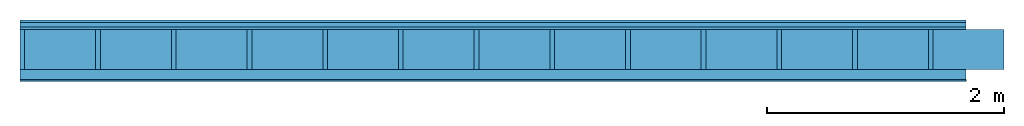
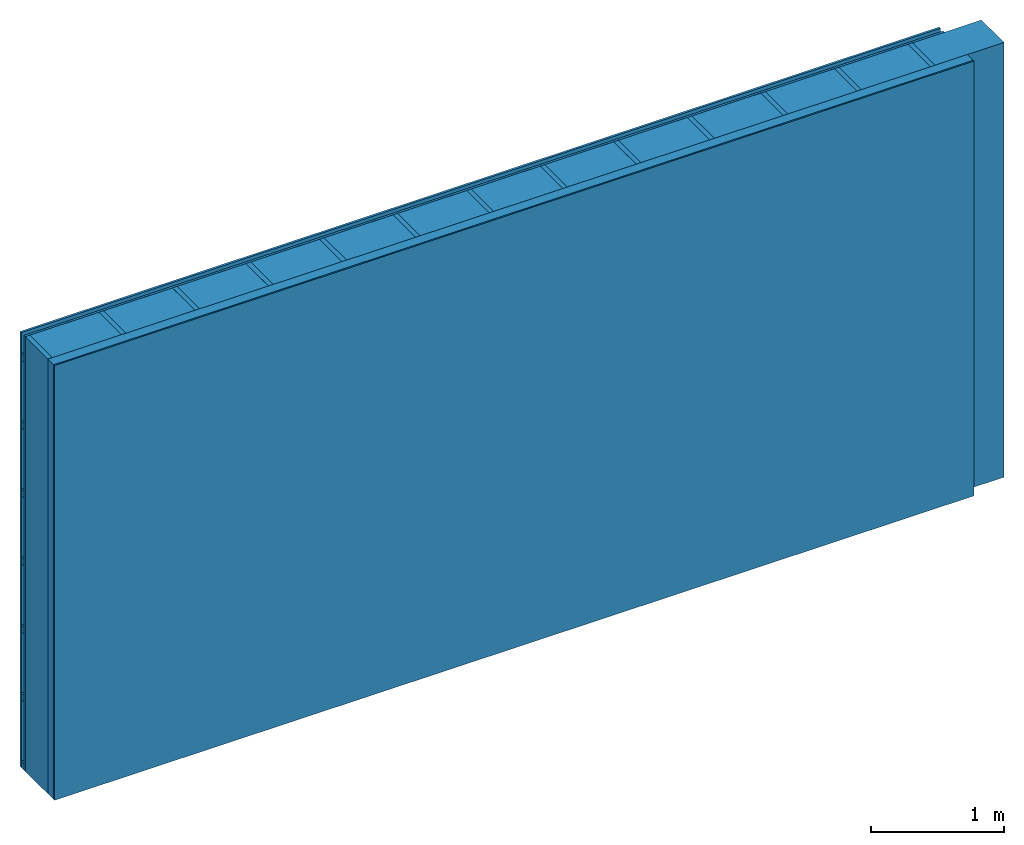
# One storey: 4 plates, 3 members, 1 element without a shape of its own.
"""IFC4 building model written with IfcOpenShell, lengths in metres."""

from ifc_helpers import new_model, si_unit, derived_unit, direction, frame, frame_2d, origin, origin_with_axes, place, context, project, spatial, rectangle, extrude, material, layer, layer_set, type_object, element, aggregate, save


model = new_model("IFC4")

# Units and contexts
plan_context = context("Plan", 3, precision=1e-05, world=origin(), true_north=direction((0.0, 1.0)))
model_context = context("Model", 3, precision=1e-05, world=origin(), true_north=direction((0.0, 1.0)))
ifc_project = project(units=[si_unit("LENGTHUNIT", "METRE"), derived_unit("SOUNDPRESSUREUNIT", [(si_unit("PRESSUREUNIT", "PASCAL", prefix="MICRO"), 0)]), si_unit("ENERGYUNIT", "JOULE", prefix="MEGA"), si_unit("MASSUNIT", "GRAM", prefix="KILO"), derived_unit("THERMALTRANSMITTANCEUNIT", [(si_unit("POWERUNIT", "WATT"), 1), (si_unit("AREAUNIT", "SQUARE_METRE"), -1), (si_unit("THERMODYNAMICTEMPERATUREUNIT", "KELVIN"), -1)]), derived_unit("AREADENSITYUNIT", [(si_unit("MASSUNIT", "GRAM", prefix="KILO"), 1), (si_unit("AREAUNIT", "SQUARE_METRE"), -1)]), derived_unit("USERDEFINED", [(si_unit("ENERGYUNIT", "JOULE", prefix="MEGA"), 1), (si_unit("AREAUNIT", "SQUARE_METRE"), -1)])], contexts=[plan_context, model_context])

# Site, building, storey
site = spatial("IfcSite", under=ifc_project)
building_placement = place(None, origin())
building = spatial("IfcBuilding", under=site, at=building_placement)
storey_placement = place(building_placement, origin())
storey = spatial("IfcBuildingStorey", under=building, at=storey_placement)

# Wall, members, plates
ifc_material_1 = material(Name="Wood cladding horizontal, closed")
ifc_layer_1 = layer(ifc_material_1, 0.02, Name="Cover 1st layer")
ifc_layer_2 = layer(None, 0.04, Name="Battens / profiles (ventilation)")
ifc_material_2 = material(Category="10.009")
ifc_layer_3 = layer(ifc_material_2, 0.02, Name="outside 1st layer")
ifc_material_3 = material(Name="of the art")
ifc_layer_4 = layer(ifc_material_3, 0.0, Name="Bond")
ifc_layer_5 = layer(None, 0.34, Name="Support")
ifc_layer_6 = layer(ifc_material_3, 0.0, Name="Bond")
ifc_material_4 = material(Name="Solid timber panel")
ifc_layer_7 = layer(ifc_material_4, 0.087, Name="1st layer")
ifc_material_5 = material(Name="Plasterboard type A", Category="03.008")
ifc_layer_8 = layer(ifc_material_5, 0.0125, Name="Covering 1st layer")
ifc_material_6 = material(Name="joints", Category="04.017")
ifc_layer_9 = layer(ifc_material_6, 0.0, Name="Surface")
ifc_layer_set = layer_set([ifc_layer_1, ifc_layer_2, ifc_layer_3, ifc_layer_4, ifc_layer_5, ifc_layer_6, ifc_layer_7, ifc_layer_8, ifc_layer_9])
wall_type = type_object("IfcWallType", Name="D1018", PredefinedType="NOTDEFINED", material=ifc_layer_set)
wall_placement = place(None, frame((0.0, 0.0, 0.0), z_axis=(0.0, -1.0, 0.0), x_axis=(1.0, 0.0, 0.0)))
wall = element("IfcWall", 1, at=wall_placement, inside=storey, type_object=wall_type, material=ifc_layer_set, Name="Wall #1")
ifc_material_7 = material()
member_1_placement = place(wall_placement, origin())
member_1 = element("IfcMember", 2, at=member_1_placement, material=ifc_material_7, Name="Battens / profiles (ventilation)", context=plan_context, shape_type="SweptSolid", body=[
    extrude(rectangle(XDim=0.06, YDim=0.04, at=frame_2d((0.03, 0.02), x_axis=(1.0, 0.0))), frame((0.0, 0.0, 0.02), z_axis=(1.0, 0.0, 0.0), x_axis=(0.0, 1.0, 0.0)), (0.0, 0.0, 1.0), 8.0),
    extrude(rectangle(XDim=0.06, YDim=0.04, at=frame_2d((0.03, 0.02), x_axis=(1.0, 0.0))), frame((0.0, 0.625, 0.02), z_axis=(1.0, 0.0, 0.0), x_axis=(0.0, 1.0, 0.0)), (0.0, 0.0, 1.0), 8.0),
    extrude(rectangle(XDim=0.06, YDim=0.04, at=frame_2d((0.03, 0.02), x_axis=(1.0, 0.0))), frame((0.0, 1.25, 0.02), z_axis=(1.0, 0.0, 0.0), x_axis=(0.0, 1.0, 0.0)), (0.0, 0.0, 1.0), 8.0),
    extrude(rectangle(XDim=0.06, YDim=0.04, at=frame_2d((0.03, 0.02), x_axis=(1.0, 0.0))), frame((0.0, 1.875, 0.02), z_axis=(1.0, 0.0, 0.0), x_axis=(0.0, 1.0, 0.0)), (0.0, 0.0, 1.0), 8.0),
    extrude(rectangle(XDim=0.06, YDim=0.04, at=frame_2d((0.03, 0.02), x_axis=(1.0, 0.0))), frame((0.0, 2.5, 0.02), z_axis=(1.0, 0.0, 0.0), x_axis=(0.0, 1.0, 0.0)), (0.0, 0.0, 1.0), 8.0),
    extrude(rectangle(XDim=0.06, YDim=0.04, at=frame_2d((0.03, 0.02), x_axis=(1.0, 0.0))), frame((0.0, 3.125, 0.02), z_axis=(1.0, 0.0, 0.0), x_axis=(0.0, 1.0, 0.0)), (0.0, 0.0, 1.0), 8.0),
    extrude(rectangle(XDim=0.06, YDim=0.04, at=frame_2d((0.03, 0.02), x_axis=(1.0, 0.0))), frame((0.0, 3.75, 0.02), z_axis=(1.0, 0.0, 0.0), x_axis=(0.0, 1.0, 0.0)), (0.0, 0.0, 1.0), 8.0),
])
ifc_material_8 = material()
member_2_placement = place(wall_placement, origin())
member_2 = element("IfcMember", 3, at=member_2_placement, material=ifc_material_8, Name="Support", context=plan_context, shape_type="SweptSolid", body=[
    extrude(rectangle(XDim=0.04, YDim=0.34, at=frame_2d((0.02, 0.17), x_axis=(1.0, 0.0))), frame((0.0, 4.0, 0.08), z_axis=(0.0, -1.0, 0.0), x_axis=(1.0, 0.0, 0.0)), (0.0, 0.0, 1.0), 4.0),
    extrude(rectangle(XDim=0.04, YDim=0.34, at=frame_2d((0.02, 0.17), x_axis=(1.0, 0.0))), frame((0.64, 4.0, 0.08), z_axis=(0.0, -1.0, 0.0), x_axis=(1.0, 0.0, 0.0)), (0.0, 0.0, 1.0), 4.0),
    extrude(rectangle(XDim=0.04, YDim=0.34, at=frame_2d((0.02, 0.17), x_axis=(1.0, 0.0))), frame((1.28, 4.0, 0.08), z_axis=(0.0, -1.0, 0.0), x_axis=(1.0, 0.0, 0.0)), (0.0, 0.0, 1.0), 4.0),
    extrude(rectangle(XDim=0.04, YDim=0.34, at=frame_2d((0.02, 0.17), x_axis=(1.0, 0.0))), frame((1.92, 4.0, 0.08), z_axis=(0.0, -1.0, 0.0), x_axis=(1.0, 0.0, 0.0)), (0.0, 0.0, 1.0), 4.0),
    extrude(rectangle(XDim=0.04, YDim=0.34, at=frame_2d((0.02, 0.17), x_axis=(1.0, 0.0))), frame((2.56, 4.0, 0.08), z_axis=(0.0, -1.0, 0.0), x_axis=(1.0, 0.0, 0.0)), (0.0, 0.0, 1.0), 4.0),
    extrude(rectangle(XDim=0.04, YDim=0.34, at=frame_2d((0.02, 0.17), x_axis=(1.0, 0.0))), frame((3.2, 4.0, 0.08), z_axis=(0.0, -1.0, 0.0), x_axis=(1.0, 0.0, 0.0)), (0.0, 0.0, 1.0), 4.0),
    extrude(rectangle(XDim=0.04, YDim=0.34, at=frame_2d((0.02, 0.17), x_axis=(1.0, 0.0))), frame((3.84, 4.0, 0.08), z_axis=(0.0, -1.0, 0.0), x_axis=(1.0, 0.0, 0.0)), (0.0, 0.0, 1.0), 4.0),
    extrude(rectangle(XDim=0.04, YDim=0.34, at=frame_2d((0.02, 0.17), x_axis=(1.0, 0.0))), frame((4.48, 4.0, 0.08), z_axis=(0.0, -1.0, 0.0), x_axis=(1.0, 0.0, 0.0)), (0.0, 0.0, 1.0), 4.0),
    extrude(rectangle(XDim=0.04, YDim=0.34, at=frame_2d((0.02, 0.17), x_axis=(1.0, 0.0))), frame((5.12, 4.0, 0.08), z_axis=(0.0, -1.0, 0.0), x_axis=(1.0, 0.0, 0.0)), (0.0, 0.0, 1.0), 4.0),
    extrude(rectangle(XDim=0.04, YDim=0.34, at=frame_2d((0.02, 0.17), x_axis=(1.0, 0.0))), frame((5.76, 4.0, 0.08), z_axis=(0.0, -1.0, 0.0), x_axis=(1.0, 0.0, 0.0)), (0.0, 0.0, 1.0), 4.0),
    extrude(rectangle(XDim=0.04, YDim=0.34, at=frame_2d((0.02, 0.17), x_axis=(1.0, 0.0))), frame((6.4, 4.0, 0.08), z_axis=(0.0, -1.0, 0.0), x_axis=(1.0, 0.0, 0.0)), (0.0, 0.0, 1.0), 4.0),
    extrude(rectangle(XDim=0.04, YDim=0.34, at=frame_2d((0.02, 0.17), x_axis=(1.0, 0.0))), frame((7.04, 4.0, 0.08), z_axis=(0.0, -1.0, 0.0), x_axis=(1.0, 0.0, 0.0)), (0.0, 0.0, 1.0), 4.0),
    extrude(rectangle(XDim=0.04, YDim=0.34, at=frame_2d((0.02, 0.17), x_axis=(1.0, 0.0))), frame((7.68, 4.0, 0.08), z_axis=(0.0, -1.0, 0.0), x_axis=(1.0, 0.0, 0.0)), (0.0, 0.0, 1.0), 4.0),
])
ifc_material_9 = material(Name="wool")
member_3_placement = place(wall_placement, origin())
member_3 = element("IfcMember", 4, at=member_3_placement, material=ifc_material_9, Name="Cavity", context=plan_context, shape_type="SweptSolid", body=[
    extrude(rectangle(XDim=0.6, YDim=0.34, at=frame_2d((0.3, 0.17), x_axis=(1.0, 0.0))), frame((0.04, 4.0, 0.08), z_axis=(0.0, -1.0, 0.0), x_axis=(1.0, 0.0, 0.0)), (0.0, 0.0, 1.0), 4.0),
    extrude(rectangle(XDim=0.6, YDim=0.34, at=frame_2d((0.3, 0.17), x_axis=(1.0, 0.0))), frame((0.68, 4.0, 0.08), z_axis=(0.0, -1.0, 0.0), x_axis=(1.0, 0.0, 0.0)), (0.0, 0.0, 1.0), 4.0),
    extrude(rectangle(XDim=0.6, YDim=0.34, at=frame_2d((0.3, 0.17), x_axis=(1.0, 0.0))), frame((1.32, 4.0, 0.08), z_axis=(0.0, -1.0, 0.0), x_axis=(1.0, 0.0, 0.0)), (0.0, 0.0, 1.0), 4.0),
    extrude(rectangle(XDim=0.6, YDim=0.34, at=frame_2d((0.3, 0.17), x_axis=(1.0, 0.0))), frame((1.96, 4.0, 0.08), z_axis=(0.0, -1.0, 0.0), x_axis=(1.0, 0.0, 0.0)), (0.0, 0.0, 1.0), 4.0),
    extrude(rectangle(XDim=0.6, YDim=0.34, at=frame_2d((0.3, 0.17), x_axis=(1.0, 0.0))), frame((2.6, 4.0, 0.08), z_axis=(0.0, -1.0, 0.0), x_axis=(1.0, 0.0, 0.0)), (0.0, 0.0, 1.0), 4.0),
    extrude(rectangle(XDim=0.6, YDim=0.34, at=frame_2d((0.3, 0.17), x_axis=(1.0, 0.0))), frame((3.24, 4.0, 0.08), z_axis=(0.0, -1.0, 0.0), x_axis=(1.0, 0.0, 0.0)), (0.0, 0.0, 1.0), 4.0),
    extrude(rectangle(XDim=0.6, YDim=0.34, at=frame_2d((0.3, 0.17), x_axis=(1.0, 0.0))), frame((3.88, 4.0, 0.08), z_axis=(0.0, -1.0, 0.0), x_axis=(1.0, 0.0, 0.0)), (0.0, 0.0, 1.0), 4.0),
    extrude(rectangle(XDim=0.6, YDim=0.34, at=frame_2d((0.3, 0.17), x_axis=(1.0, 0.0))), frame((4.52, 4.0, 0.08), z_axis=(0.0, -1.0, 0.0), x_axis=(1.0, 0.0, 0.0)), (0.0, 0.0, 1.0), 4.0),
    extrude(rectangle(XDim=0.6, YDim=0.34, at=frame_2d((0.3, 0.17), x_axis=(1.0, 0.0))), frame((5.16, 4.0, 0.08), z_axis=(0.0, -1.0, 0.0), x_axis=(1.0, 0.0, 0.0)), (0.0, 0.0, 1.0), 4.0),
    extrude(rectangle(XDim=0.6, YDim=0.34, at=frame_2d((0.3, 0.17), x_axis=(1.0, 0.0))), frame((5.8, 4.0, 0.08), z_axis=(0.0, -1.0, 0.0), x_axis=(1.0, 0.0, 0.0)), (0.0, 0.0, 1.0), 4.0),
    extrude(rectangle(XDim=0.6, YDim=0.34, at=frame_2d((0.3, 0.17), x_axis=(1.0, 0.0))), frame((6.44, 4.0, 0.08), z_axis=(0.0, -1.0, 0.0), x_axis=(1.0, 0.0, 0.0)), (0.0, 0.0, 1.0), 4.0),
    extrude(rectangle(XDim=0.6, YDim=0.34, at=frame_2d((0.3, 0.17), x_axis=(1.0, 0.0))), frame((7.08, 4.0, 0.08), z_axis=(0.0, -1.0, 0.0), x_axis=(1.0, 0.0, 0.0)), (0.0, 0.0, 1.0), 4.0),
    extrude(rectangle(XDim=0.6, YDim=0.34, at=frame_2d((0.3, 0.17), x_axis=(1.0, 0.0))), frame((7.72, 4.0, 0.08), z_axis=(0.0, -1.0, 0.0), x_axis=(1.0, 0.0, 0.0)), (0.0, 0.0, 1.0), 4.0),
])
plate_1_placement = place(wall_placement, origin())
plate_1 = element("IfcPlate", 5, at=plate_1_placement, material=ifc_material_1, Name="Cover 1st layer", context=plan_context, shape_type="SweptSolid", body=[
    extrude(rectangle(XDim=8.0, YDim=4.0, at=frame_2d((4.0, 2.0), x_axis=(1.0, 0.0))), origin_with_axes(), (0.0, 0.0, 1.0), 0.02),
])
plate_2_placement = place(wall_placement, origin())
plate_2 = element("IfcPlate", 6, at=plate_2_placement, material=ifc_material_2, Name="outside 1st layer", context=plan_context, shape_type="SweptSolid", body=[
    extrude(rectangle(XDim=8.0, YDim=4.0, at=frame_2d((4.0, 2.0), x_axis=(1.0, 0.0))), frame((0.0, 0.0, 0.06), z_axis=(0.0, 0.0, 1.0), x_axis=(1.0, 0.0, 0.0)), (0.0, 0.0, 1.0), 0.02),
])
plate_3_placement = place(wall_placement, origin())
plate_3 = element("IfcPlate", 7, at=plate_3_placement, material=ifc_material_4, Name="1st layer", context=plan_context, shape_type="SweptSolid", body=[
    extrude(rectangle(XDim=8.0, YDim=4.0, at=frame_2d((4.0, 2.0), x_axis=(1.0, 0.0))), frame((0.0, 0.0, 0.42), z_axis=(0.0, 0.0, 1.0), x_axis=(1.0, 0.0, 0.0)), (0.0, 0.0, 1.0), 0.087),
])
plate_4_placement = place(wall_placement, origin())
plate_4 = element("IfcPlate", 8, at=plate_4_placement, material=ifc_material_5, Name="Covering 1st layer", context=plan_context, shape_type="SweptSolid", body=[
    extrude(rectangle(XDim=8.0, YDim=4.0, at=frame_2d((4.0, 2.0), x_axis=(1.0, 0.0))), frame((0.0, 0.0, 0.507), z_axis=(0.0, 0.0, 1.0), x_axis=(1.0, 0.0, 0.0)), (0.0, 0.0, 1.0), 0.0125),
])
aggregate(wall, [plate_1, member_1, plate_2, member_2, member_3, plate_3, plate_4])

save(model, "model.ifc")
